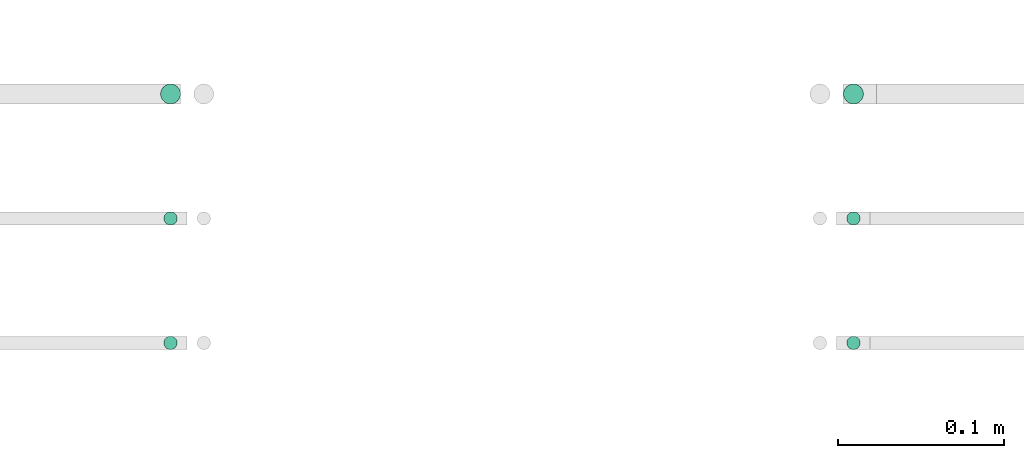
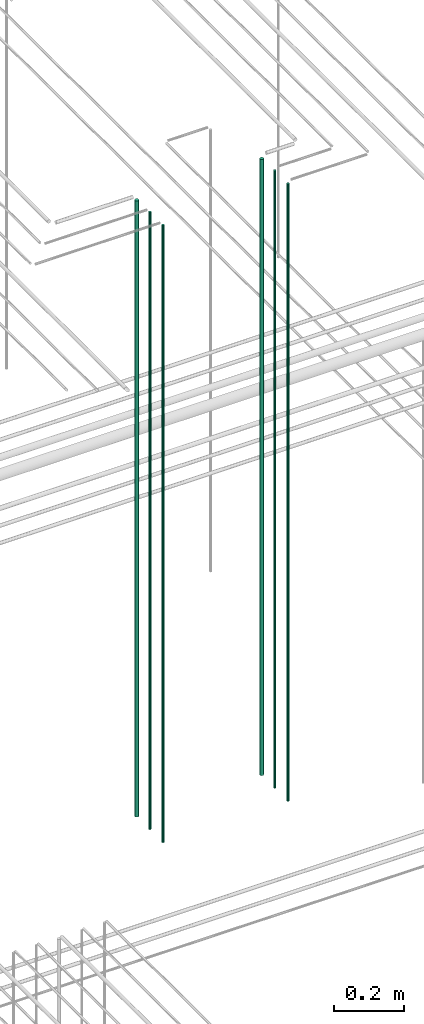
# One storey, part 13 of 331: 6 flow segments.
"""IFC2X3 building model written with IfcOpenShell, lengths in millimetres."""

from ifc_helpers import new_model, entity, si_unit, converted_unit, derived_unit, direction, frame, frame_2d, origin, origin_2d_with_axis, place, context, subcontext, project, spatial, circle, extrude, type_object, element, save


model = new_model("IFC2X3")

# Units and contexts
model_context = context("Model", 3, precision=0.01, world=origin(), true_north=direction((6.12303176911189e-17, 1.0)))
body_context = subcontext(model_context, "Body", "Model", "MODEL_VIEW")
ifc_project = project(units=[si_unit("LENGTHUNIT", "METRE", prefix="MILLI"), si_unit("AREAUNIT", "SQUARE_METRE"), si_unit("VOLUMEUNIT", "CUBIC_METRE"), converted_unit("PLANEANGLEUNIT", "DEGREE", entity("IfcRatioMeasure", 0.0174532925199433), si_unit("PLANEANGLEUNIT", "RADIAN"), dimensions=[0, 0, 0, 0, 0, 0, 0]), si_unit("MASSUNIT", "GRAM", prefix="KILO"), derived_unit("MASSDENSITYUNIT", [(si_unit("MASSUNIT", "GRAM", prefix="KILO"), 1), (si_unit("LENGTHUNIT", "METRE"), -3)]), derived_unit("MOMENTOFINERTIAUNIT", [(si_unit("LENGTHUNIT", "METRE"), 4)]), si_unit("TIMEUNIT", "SECOND"), si_unit("FREQUENCYUNIT", "HERTZ"), si_unit("THERMODYNAMICTEMPERATUREUNIT", "DEGREE_CELSIUS"), derived_unit("THERMALTRANSMITTANCEUNIT", [(si_unit("MASSUNIT", "GRAM", prefix="KILO"), 1), (si_unit("THERMODYNAMICTEMPERATUREUNIT", "KELVIN"), -1), (si_unit("TIMEUNIT", "SECOND"), -3)]), derived_unit("VOLUMETRICFLOWRATEUNIT", [(si_unit("LENGTHUNIT", "METRE"), 3), (si_unit("TIMEUNIT", "SECOND"), -1)]), derived_unit("MASSFLOWRATEUNIT", [(si_unit("MASSUNIT", "GRAM", prefix="KILO"), 1), (si_unit("TIMEUNIT", "SECOND"), -1)]), derived_unit("ROTATIONALFREQUENCYUNIT", [(si_unit("TIMEUNIT", "SECOND"), -1)]), si_unit("ELECTRICCURRENTUNIT", "AMPERE"), si_unit("ELECTRICVOLTAGEUNIT", "VOLT"), si_unit("POWERUNIT", "WATT"), si_unit("FORCEUNIT", "NEWTON", prefix="KILO"), si_unit("ILLUMINANCEUNIT", "LUX"), si_unit("LUMINOUSFLUXUNIT", "LUMEN"), si_unit("LUMINOUSINTENSITYUNIT", "CANDELA"), derived_unit("USERDEFINED", [(si_unit("MASSUNIT", "GRAM", prefix="KILO"), -1), (si_unit("LENGTHUNIT", "METRE"), -2), (si_unit("TIMEUNIT", "SECOND"), 3), (si_unit("LUMINOUSFLUXUNIT", "LUMEN"), 1)]), derived_unit("LINEARVELOCITYUNIT", [(si_unit("LENGTHUNIT", "METRE"), 1), (si_unit("TIMEUNIT", "SECOND"), -1)]), si_unit("PRESSUREUNIT", "PASCAL"), derived_unit("USERDEFINED", [(si_unit("LENGTHUNIT", "METRE"), -2), (si_unit("MASSUNIT", "GRAM", prefix="KILO"), 1), (si_unit("TIMEUNIT", "SECOND"), -2)]), derived_unit("LINEARFORCEUNIT", [(si_unit("MASSUNIT", "GRAM", prefix="KILO"), 1), (si_unit("LENGTHUNIT", "METRE"), 1), (si_unit("TIMEUNIT", "SECOND"), -2), (si_unit("LENGTHUNIT", "METRE"), -1)]), derived_unit("PLANARFORCEUNIT", [(si_unit("MASSUNIT", "GRAM", prefix="KILO"), 1), (si_unit("LENGTHUNIT", "METRE"), 1), (si_unit("TIMEUNIT", "SECOND"), -2), (si_unit("LENGTHUNIT", "METRE"), -2)])], contexts=[model_context])

# Site, building, storey
site_placement = place(None, frame((0.0, -0.00077364408347762, 0.0)))
site = spatial("IfcSite", under=ifc_project, at=site_placement, CompositionType="ELEMENT")
building_placement = place(site_placement, origin())
building = spatial("IfcBuilding", under=site, at=building_placement, CompositionType="ELEMENT")
storey_placement = place(building_placement, origin())
storey = spatial("IfcBuildingStorey", under=building, at=storey_placement, CompositionType="ELEMENT", Elevation=0.0)

# Flow segments
pipe_segment_type = type_object("IfcPipeSegmentType", PredefinedType="NOTDEFINED")
flow_segment_1_placement = place(storey_placement, frame((25969.3494489383, 3883.89349484379, 16890.0)))
element("IfcFlowSegment", 1, at=flow_segment_1_placement, inside=storey, type_object=pipe_segment_type, context=body_context, shape_type="SweptSolid", body=[
    extrude(circle(Radius=6.0, at=origin_2d_with_axis()), frame((7.59527223591454, 7.59527223591616, 0.0)), (0.0, 0.0, 1.0), 2146.0),
])
for number, where in (
    (2, (25971.3494489383, 3735.89349484379, 16890.0)),
    (3, (25971.3494489383, 3810.89349484379, 16890.0)),
):
    element("IfcFlowSegment", number, at=place(storey_placement, frame(where)), inside=storey, type_object=pipe_segment_type, context=body_context, shape_type="SweptSolid", body=[
        extrude(circle(Radius=4.0, at=origin_2d_with_axis()), frame((5.59527223591499, 5.59527223591607, 0.0)), (0.0, 0.0, 1.0), 2150.00000000001),
    ])
flow_segment_2_placement = place(storey_placement, frame((25557.8400885061, 3883.89349484383, 16890.0)))
element("IfcFlowSegment", 4, at=flow_segment_2_placement, inside=storey, type_object=pipe_segment_type, context=body_context, shape_type="SweptSolid", body=[
    extrude(circle(Radius=6.0, at=frame_2d((0.0, -5.41433564649196e-13), x_axis=(1.0, 0.0))), frame((7.59527223591454, 7.5952722359167, 0.0)), (0.0, 0.0, 1.0), 2145.99999999998),
])
for number, where in (
    (5, (25559.840088506, 3735.89349484383, 16890.0)),
    (6, (25559.8400885062, 3810.89349484382, 16890.0)),
):
    element("IfcFlowSegment", number, at=place(storey_placement, frame(where)), inside=storey, type_object=pipe_segment_type, context=body_context, shape_type="SweptSolid", body=[
        extrude(circle(Radius=4.0, at=origin_2d_with_axis()), frame((5.59527223591499, 5.59527223591607, 0.0)), (0.0, 0.0, 1.0), 2150.00000000001),
    ])

save(model, "model.ifc")
